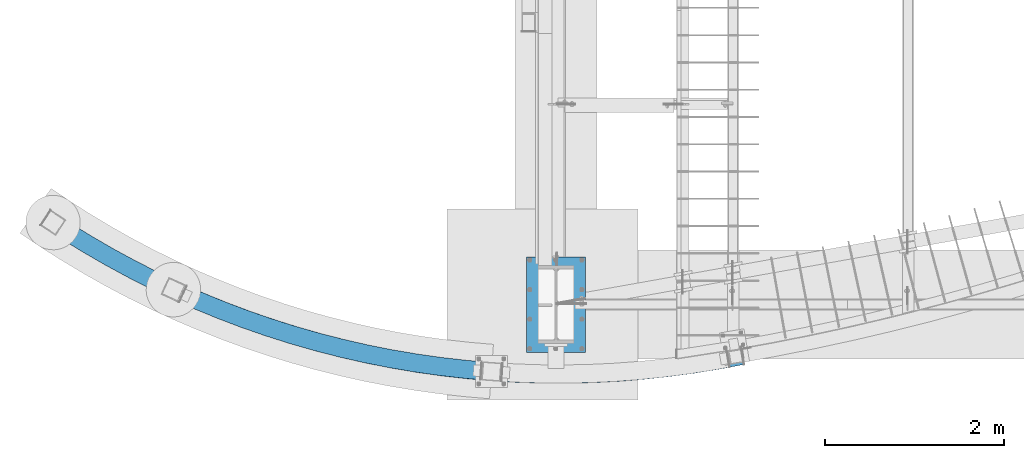
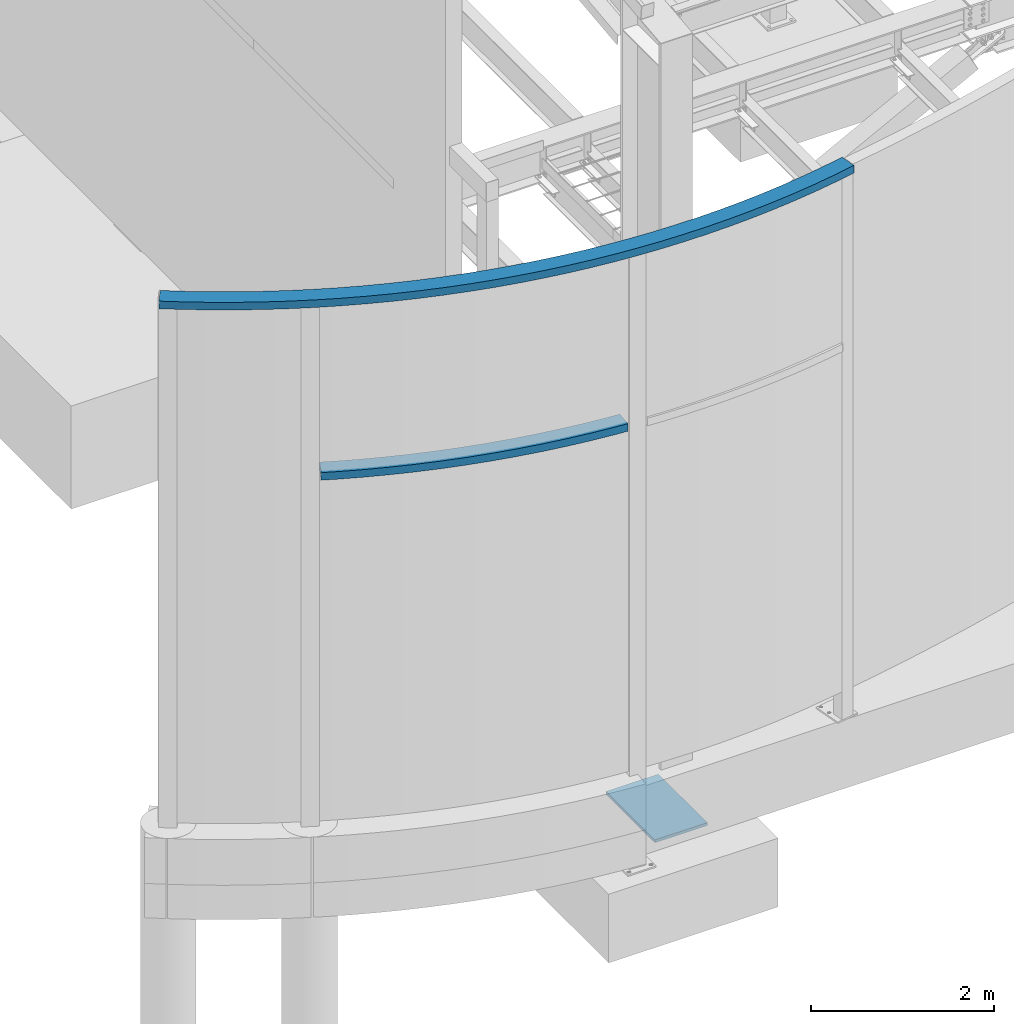
# One storey, part 700 of 1179: 3 beams, 3 elements without a shape of their own.
"""IFC2X3 building model written with IfcOpenShell, lengths in millimetres."""

import ifcopenshell
import ifcopenshell.guid

model = None  # the IFC model being written
_history = None  # IfcOwnerHistory: only IFC2X3 demands one
_inside = {}  # id of a spatial element -> (the spatial element, [elements in it])
_under = {}  # id of a project, library or spatial element -> (it, [spatial elements below it])
_declared = {}  # id of a project -> (the project, [libraries it declares])
_typed = {}  # id of a type object -> (the type object, [elements of that type])
_made_of = {}  # id of a material, layer set ... -> (it, [elements and type objects made of it])


def new_model(schema):
    """Start an empty IFC model of exactly this schema.

    Asked for "IFC4X3", IfcOpenShell would pick the latest addendum, in which some entities
    have other attributes; the version numbers below select the first issue.
    IFC2X3 requires an IfcOwnerHistory on every rooted entity: one is made here for all.
    """
    global model, _history
    if schema == "IFC4X3":
        model = ifcopenshell.file(schema_version=(4, 3, 0, 0))
    else:
        model = ifcopenshell.file(schema=schema)
    _inside.clear()
    _under.clear()
    _declared.clear()
    _typed.clear()
    _made_of.clear()
    _history = None
    if model.schema == "IFC2X3":
        org = make("IfcOrganization", Name="unknown")
        user = make(
            "IfcPersonAndOrganization",
            ThePerson=make("IfcPerson", FamilyName="unknown"),
            TheOrganization=org,
        )
        app = make(
            "IfcApplication",
            ApplicationDeveloper=org,
            Version="unknown",
            ApplicationFullName="unknown",
            ApplicationIdentifier="unknown",
        )
        _history = make(
            "IfcOwnerHistory",
            OwningUser=user,
            OwningApplication=app,
            ChangeAction="ADDED",
            CreationDate=0,
        )
    return model


def make(cls, **values):
    """One entity of the class cls with the attributes given. An attribute that is None is left unset."""
    return model.create_entity(
        cls, **{name: value for name, value in values.items() if value is not None}
    )


def rooted(cls, **values):
    """An entity with a GlobalId (a new one), such as an element, a storey or a relation."""
    return make(cls, GlobalId=ifcopenshell.guid.new(), OwnerHistory=_history, **values)


def si_unit(unit_type, name, prefix=None):
    """IfcSIUnit, for example si_unit("LENGTHUNIT", "METRE", prefix="MILLI")."""
    return make("IfcSIUnit", UnitType=unit_type, Prefix=prefix, Name=name)


def assignment(units):
    """IfcUnitAssignment: the units of a project."""
    return None if units is None else make("IfcUnitAssignment", Units=units)


def point(xyz):
    """IfcCartesianPoint."""
    return None if xyz is None else make("IfcCartesianPoint", Coordinates=xyz)


def direction(xyz):
    """IfcDirection."""
    return None if xyz is None else make("IfcDirection", DirectionRatios=xyz)


def frame(location, z_axis=None, x_axis=None):
    """IfcAxis2Placement3D, a coordinate frame: its origin and axes. An axis left out is left unset."""
    return make(
        "IfcAxis2Placement3D",
        Location=point(location),
        Axis=direction(z_axis),
        RefDirection=direction(x_axis),
    )


def origin_with_axes():
    """The frame at (0, 0, 0) with the z axis (0, 0, 1) and the x axis (1, 0, 0) written out."""
    return frame((0.0, 0.0, 0.0), z_axis=(0.0, 0.0, 1.0), x_axis=(1.0, 0.0, 0.0))


def place(relative_to, where):
    """IfcLocalPlacement: puts the frame where relative to a parent placement (None: the world)."""
    return make(
        "IfcLocalPlacement", PlacementRelTo=relative_to, RelativePlacement=where
    )


def context(
    kind, dimensions, precision=None, world=None, true_north=None, identifier=None
):
    """IfcGeometricRepresentationContext, for example the 3D "Model" context."""
    return make(
        "IfcGeometricRepresentationContext",
        ContextIdentifier=identifier,
        ContextType=kind,
        CoordinateSpaceDimension=dimensions,
        Precision=precision,
        WorldCoordinateSystem=world,
        TrueNorth=true_north,
    )


def subcontext(parent, identifier, kind, view, scale=None):
    """IfcGeometricRepresentationSubContext, for example "Body" below "Model"."""
    return make(
        "IfcGeometricRepresentationSubContext",
        ContextIdentifier=identifier,
        ContextType=kind,
        ParentContext=parent,
        TargetScale=scale,
        TargetView=view,
    )


def project(units=None, contexts=None):
    """IfcProject with its units and contexts."""
    return rooted(
        "IfcProject",
        Name="project",
        RepresentationContexts=contexts,
        UnitsInContext=assignment(units),
    )


def spatial(cls, under=None, at=None, **own):
    """A site, building, storey or space (cls), placed at a placement, below another one or the project."""
    s = rooted(cls, ObjectPlacement=at, **own)
    if under is not None:
        _under.setdefault(under.id(), (under, []))[1].append(s)
    return s


def faces_of(points, faces, orient=None, outer=None):
    """IfcFace entities. A face is a list of loops; a loop is a list of indices into points, from 0.

    orient and outer hold one flag for each loop. By default every Orientation is true, the
    first loop of a face is its IfcFaceOuterBound and the others are IfcFaceBound.
    """
    made = []
    for i, loops in enumerate(faces):
        bounds = []
        for j, loop in enumerate(loops):
            is_outer = j == 0 if outer is None else outer[i][j]
            bounds.append(
                make(
                    "IfcFaceOuterBound" if is_outer else "IfcFaceBound",
                    Bound=make("IfcPolyLoop", Polygon=[points[k] for k in loop]),
                    Orientation=True if orient is None else orient[i][j],
                )
            )
        made.append(make("IfcFace", Bounds=bounds))
    return made


def faceted_brep(points, faces, orient=None, outer=None, voids=None):
    """IfcFacetedBrep: a solid bounded by flat faces; with voids (closed shells), ...WithVoids."""
    shared = [point(p) for p in points]
    hull = make("IfcClosedShell", CfsFaces=faces_of(shared, faces, orient, outer))
    if voids is None:
        return make("IfcFacetedBrep", Outer=hull)
    return make(
        "IfcFacetedBrepWithVoids",
        Outer=hull,
        Voids=[
            make(cls, CfsFaces=faces_of(shared, fs, o, b)) for cls, fs, o, b in voids
        ],
    )


def shape(context_of_items, identifier, shape_type, items):
    """IfcShapeRepresentation: the items that make up one representation, for example the "Body"."""
    return make(
        "IfcShapeRepresentation",
        ContextOfItems=context_of_items,
        RepresentationIdentifier=identifier,
        RepresentationType=shape_type,
        Items=items,
    )


def material(Name=None, Category=None):
    """IfcMaterial."""
    return make("IfcMaterial", Name=Name, Category=Category)


def made_of(thing, what):
    """Note that an element or type object is made of a material, layer set ...; save() writes the relation."""
    if what is not None:
        _made_of.setdefault(what.id(), (what, []))[1].append(thing)
    return thing


def type_object(cls, material=None, **own):
    """A type object (cls), such as IfcWallType, which elements share."""
    return made_of(rooted(cls, **own), material)


def element(
    cls,
    number,
    at=None,
    inside=None,
    cuts=None,
    type_object=None,
    material=None,
    context=None,
    identifier="Body",
    shape_type=None,
    held_by="IfcProductDefinitionShape",
    body=None,
    shapes=None,
    **own,
):
    """One element of the class cls, such as IfcWall. Its Tag is "e" and its number.

    at: its placement. inside: the storey or other place that contains it. cuts: it is an
    opening in that element (IfcRelVoidsElement). A single representation is given by context,
    identifier, shape_type and body (its items); several are given by shapes. held_by: the class
    of the entity that holds the representations. save() writes the other relations.
    """
    e = rooted(cls, Tag="e%d" % number, ObjectPlacement=at, **own)
    if body is not None:
        shapes = [shape(context, identifier, shape_type, body)]
    if shapes is not None:
        e.Representation = make(held_by, Representations=shapes)
    if inside is not None:
        _inside.setdefault(inside.id(), (inside, []))[1].append(e)
    if cuts is not None:
        rooted(
            "IfcRelVoidsElement", RelatingBuildingElement=cuts, RelatedOpeningElement=e
        )
    if type_object is not None:
        _typed.setdefault(type_object.id(), (type_object, []))[1].append(e)
    return made_of(e, material)


def aggregate(whole, parts):
    """IfcRelAggregates: a whole, such as a stair, and the parts it consists of."""
    return rooted("IfcRelAggregates", RelatingObject=whole, RelatedObjects=parts)


def save(model, path):
    """Write the relations noted so far, then the file.

    IfcRelAggregates (storeys below a building ...), IfcRelContainedInSpatialStructure (elements
    in a storey), IfcRelDefinesByType, IfcRelAssociatesMaterial and IfcRelDeclares: one each for
    every whole, place, type object, material and project.
    """
    for whole, parts in _under.values():
        aggregate(whole, parts)
    for where, things in _inside.values():
        rooted(
            "IfcRelContainedInSpatialStructure",
            RelatedElements=things,
            RelatingStructure=where,
        )
    for kind, things in _typed.values():
        rooted("IfcRelDefinesByType", RelatedObjects=things, RelatingType=kind)
    for what, things in _made_of.values():
        rooted("IfcRelAssociatesMaterial", RelatedObjects=things, RelatingMaterial=what)
    for by, libraries in _declared.values():
        rooted("IfcRelDeclares", RelatingContext=by, RelatedDefinitions=libraries)
    model.write(path)


model = new_model("IFC2X3")

# Units and contexts
model_context = context("Model", 3, precision=1e-05, world=origin_with_axes())
body_context = subcontext(model_context, "Body", "Model", "MODEL_VIEW")
ifc_project = project(units=[si_unit("LENGTHUNIT", "METRE", prefix="MILLI"), si_unit("AREAUNIT", "SQUARE_METRE"), si_unit("VOLUMEUNIT", "CUBIC_METRE"), si_unit("MASSUNIT", "GRAM", prefix="KILO"), si_unit("TIMEUNIT", "SECOND"), si_unit("PLANEANGLEUNIT", "RADIAN"), si_unit("SOLIDANGLEUNIT", "STERADIAN"), si_unit("THERMODYNAMICTEMPERATUREUNIT", "DEGREE_CELSIUS"), si_unit("LUMINOUSINTENSITYUNIT", "LUMEN")], contexts=[model_context])

# Site, building, storey
site_placement = place(None, origin_with_axes())
site = spatial("IfcSite", under=ifc_project, at=site_placement, CompositionType="ELEMENT")
building_placement = place(site_placement, origin_with_axes())
building = spatial("IfcBuilding", under=site, at=building_placement, Name="Undefined", CompositionType="ELEMENT")
storey_placement = place(building_placement, origin_with_axes())
storey = spatial("IfcBuildingStorey", under=building, at=storey_placement, Name="Undefined", CompositionType="ELEMENT", Elevation=0.0)

# Assembly, beam
assembly_1_placement = place(storey_placement, origin_with_axes())
assembly_1 = element("IfcElementAssembly", 1, at=assembly_1_placement, inside=storey, Name="BEAM", AssemblyPlace="NOTDEFINED", PredefinedType="RIGID_FRAME")
ifc_material_1 = material()
beam_type_1 = type_object("IfcBeamType", Name="HSS8X4X1/4", PredefinedType="NOTDEFINED")
beam_1_placement = place(assembly_1_placement, frame((-5275.44377890832, 1410.31196065489, 6908.8), z_axis=(0.38393976093835, 0.923358142851734, 0.0), x_axis=(0.923358142851734, -0.38393976093835, 0.0)))
beam_1 = element("IfcBeam", 2, at=beam_1_placement, type_object=beam_type_1, material=ifc_material_1, Name="BEAM", ObjectType="HSS8X4X1/4", context=body_context, shape_type="Brep", body=[
    faceted_brep([(259.218046958578, 50.8000000000002, -151.867784473954), (539.821269490069, 50.8000000000002, -196.459973259438), (539.821269490069, -50.8000000000002, -196.459973259438), (259.218046958578, -50.8000000000002, -151.867784473954), (821.541401207169, 50.8000000000002, -233.343562849296), (821.541401207169, -50.8000000000002, -233.343562849296), (1104.16671573728, 50.8000000000002, -262.490833433148), (1104.16671573728, -50.8000000000002, -262.490833433148), (1387.48480641892, 50.8000000000002, -283.879879420383), (1387.48480641892, -50.8000000000002, -283.879879420383), (1671.28274593564, 50.8000000000002, -297.494625903278), (1671.28274593564, -50.8000000000002, -297.494625903278), (1955.34724634128, 50.8000000000002, -303.32484073808), (1955.34724634128, -50.8000000000002, -303.32484073808), (2239.46481935623, 50.8000000000002, -301.366142234949), (2239.46481935623, -50.8000000000002, -301.366142234949), (2523.42193681419, 50.8000000000002, -291.620002451016), (2523.42193681419, -50.8000000000002, -291.620002451016), (2807.00519113906, 50.8000000000002, -274.093746084063), (2807.00519113906, -50.8000000000002, -274.093746084063), (3090.00145573103, 50.8000000000002, -248.800544967648), (3090.00145573103, -50.8000000000002, -248.800544967648), (3372.19804514161, 50.8000000000002, -215.759408171846), (3372.19804514161, -50.8000000000002, -215.759408171846), (3653.38287491708, 50.8000000000002, -174.995167716991), (3653.38287491708, -50.8000000000002, -174.995167716991), (3933.34462099027, 50.8000000000002, -126.53845991122), (3933.34462099027, -50.8000000000002, -126.53845991122), (4211.87287850084, 50.8000000000002, -70.4257023257936), (4211.87287850084, -50.8000000000002, -70.4257023257936), (4488.75831992482, 50.8000000000002, -6.69906642551973), (4488.75831992482, -50.8000000000002, -6.69906642551973), (4763.79285239436, 50.8000000000002, 64.5935541251514), (4763.79285239436, -50.8000000000002, 64.5935541251514), (5036.76977408965, 50.8000000000002, 143.398579456546), (5036.76977408965, -50.8000000000002, 143.398579456546), (5307.48392958539, 50.8000000000002, 229.656783761633), (5307.48392958539, -50.8000000000002, 229.656783761633), (5575.73186403511, 50.8000000000002, 323.303339807115), (5575.73186403511, -50.8000000000002, 323.303339807115), (5841.31197607726, 50.8000000000002, 424.267867654227), (5841.31197607726, -50.8000000000002, 424.267867654227), (6104.02466934857, 50.8000000000002, 532.474487552688), (6104.02466934857, -50.8000000000002, 532.474487552688), (6363.67250249031, 50.8000000000002, 647.841876968034), (6363.67250249031, -50.8000000000002, 647.841876968034), (6620.06033753513, 50.8000000000002, 770.283331699435), (6620.06033753513, -50.8000000000002, 770.283331699435), (6872.99548656272, 50.8000000000002, 899.706831042125), (6872.99548656272, -50.8000000000002, 899.706831042125), (7122.2878565141, 50.8000000000002, 1036.01510694544), (7122.2878565141, -50.8000000000002, 1036.01510694544), (7367.75009205587, 50.8000000000002, 1179.10571711448), (7367.75009205587, -50.8000000000002, 1179.10571711448), (7609.1977163868, 50.8000000000002, 1328.87112200047), (7609.1977163868, -50.8000000000002, 1328.87112200047), (7499.73163759643, 50.8000000000002, 1500.06521533977), (7499.73163759643, -50.8000000000002, 1500.06521533977), (7730.0422105149, -50.8000000000002, 1651.81937094037), (7730.0422105149, 50.8000000000002, 1651.81937094037), (7263.01788799386, -50.8000000000002, 1353.23614361231), (7263.01788799386, 50.8000000000002, 1353.23614361231), (7022.36823852254, -50.8000000000002, 1212.95099912231), (7022.36823852254, 50.8000000000002, 1212.95099912231), (6777.96354909134, -50.8000000000002, 1079.31521297471), (6777.96354909134, 50.8000000000002, 1079.31521297471), (6529.98750170418, -50.8000000000002, 952.429218958454), (6529.98750170418, 50.8000000000002, 952.429218958454), (6278.62646241409, -50.8000000000002, 832.388378065614), (6278.62646241409, 50.8000000000002, 832.388378065614), (6024.06934126005, -50.8000000000002, 719.282906822975), (6024.06934126005, 50.8000000000002, 719.282906822975), (5766.50745029191, -50.8000000000002, 613.197809489906), (5766.50745029191, 50.8000000000002, 613.197809489905), (5506.13435979008, -50.8000000000002, 514.212814173549), (5506.13435979008, 50.8000000000002, 514.212814173548), (5243.14575278807, -50.8000000000002, 422.402312909265), (5243.14575278807, 50.8000000000002, 422.402312909265), (4977.73927800719, -50.8000000000002, 337.835305751407), (4977.73927800719, 50.8000000000002, 337.835305751407), (4710.11440131387, -50.8000000000002, 260.575348916414), (4710.11440131387, 50.8000000000002, 260.575348916414), (4440.47225581146, -50.8000000000002, 190.680507017236), (4440.47225581146, 50.8000000000002, 190.680507017236), (4169.01549067883, -50.8000000000002, 128.203309424948), (4169.01549067883, 50.8000000000002, 128.203309424948), (3895.94811886973, -50.8000000000002, 73.1907107903846), (3895.94811886973, 50.8000000000002, 73.1907107903846), (3621.4753637871, -50.8000000000002, 25.6840557554291), (3621.4753637871, 50.8000000000002, 25.6840557554275), (3345.80350504773, -50.8000000000002, -14.2809521195055), (3345.80350504773, 50.8000000000002, -14.2809521195055), (3069.1397234531, -50.8000000000002, -46.6742771884062), (3069.1397234531, 50.8000000000002, -46.6742771884062), (2791.69194528292, -50.8000000000002, -71.47157429294), (2791.69194528292, 50.8000000000002, -71.4715742929404), (2513.66868602843, -50.8000000000002, -88.6542070590068), (2513.66868602843, 50.8000000000002, -88.6542070590068), (2235.27889368289, -50.8000000000002, -98.2092619028816), (2235.27889368289, 50.8000000000002, -98.2092619028814), (1956.73179170698, -50.8000000000002, -100.129557736408), (1956.73179170698, 50.8000000000002, -100.129557736408), (1678.23672178722, -50.8000000000002, -94.4136513639239), (1678.23672178722, 50.8000000000002, -94.4136513639239), (1400.00298650553, -50.8000000000002, -81.0658385669027), (1400.00298650553, 50.8000000000002, -81.0658385669027), (1122.23969203811, -50.8000000000002, -60.0961508754618), (1122.23969203811, 50.8000000000002, -60.0961508754616), (845.155591002052, -50.8000000000002, -31.5203480291747), (845.155591002052, 50.8000000000002, -31.5203480291761), (568.958925567555, -50.8000000000002, 4.64009386712303), (568.958925567555, 50.8000000000002, 4.64009386712144), (293.857270953826, -50.8000000000002, 48.3579984836948), (293.857270953826, 50.8000000000002, 48.3579984836948), (25.4080125181054, 50.8000000000002, 98.5991218713883), (25.4080125181054, -50.8000000000002, 98.5991218713883), (7838.72166228527, -50.8000000000002, 1480.10696045358), (-12.9228285404379, -50.8000000000002, -100.935763337249), (-12.9228285404379, 50.8000000000002, -100.935763337249), (7838.72166228527, 50.8000000000002, 1480.10696045358), (260.30052270843, -44.4499999999998, -145.610728756527), (540.731821242491, -44.4499999999998, -190.175596161732), (540.731821242491, 44.4499999999998, -190.175596161732), (260.300522708431, 44.4499999999998, -145.610728756527), (822.279344638257, -44.4499999999998, -227.036587386168), (822.279344638258, 44.4499999999998, -227.036587386168), (1104.73149624668, -44.4499999999998, -256.165999603222), (1104.73149624668, 44.4499999999998, -256.165999603222), (1387.87599954662, -44.4499999999998, -277.541940643712), (1387.87599954662, 44.4499999999998, -277.541940643712), (1671.500057681, -44.4499999999998, -291.148345448925), (1671.500057681, 44.4499999999998, -291.148345448925), (1955.39051338396, -44.4499999999998, -296.974988144278), (1955.39051338396, 44.4499999999998, -296.974988144278), (2239.33400917893, -44.4499999999998, -295.017489724572), (2239.33400917893, 44.4499999999998, -295.017489724572), (2523.11714772714, -44.4499999999998, -285.277321345015), (2523.11714772714, 44.4499999999998, -285.277321345015), (2806.52665220606, -44.4499999999998, -267.761803215588), (2806.52665220606, 44.4499999999998, -267.761803215588), (3089.34952659735, -44.4499999999998, -242.484099099546), (3089.34952659735, 44.4499999999998, -242.484099099546), (3371.37321576368, -44.4499999999998, -209.46320642021), (3371.37321576368, 44.4499999999998, -209.463206420209), (3652.38576519427, -44.4499999999998, -168.723941983478), (3652.38576519427, 44.4499999999998, -168.723941983478), (3932.175980299, -44.4499999999998, -120.296923326795), (3932.175980299, 44.4499999999998, -120.296923326795), (4210.53358513141, -44.4499999999998, -64.2185457085832), (4210.53358513141, 44.4499999999998, -64.218545708583), (4487.24938042128, -44.4499999999998, -0.530954755433982), (4487.24938042128, 44.4499999999998, -0.530954755433982), (4762.11540079809, -44.4499999999998, 70.7179852123787), (4762.11540079809, 44.4499999999998, 70.7179852123787), (5034.92507108707, -44.4499999999998, 149.47472715326), (5034.92507108707, 44.4499999999998, 149.47472715326), (5305.47336156048, -44.4499999999998, 235.680081547496), (5305.47336156048, 44.4499999999998, 235.680081547496), (5573.55694202745, -44.4499999999998, 329.269260881064), (5573.55694202745, 44.4499999999998, 329.269260881064), (5838.97433464647, -44.4499999999998, 430.17192833659), (5838.97433464647, 44.4499999999998, 430.17192833659), (6101.5260653458, -44.4499999999998, 538.312250654885), (6101.5260653458, 44.4499999999998, 538.312250654885), (6361.01481373792, -44.4499999999998, 653.608955127335), (6361.01481373792, 44.4499999999998, 653.608955127335), (6617.24556141542, -44.4499999999998, 775.97539067628), (6617.24556141542, 44.4499999999998, 775.97539067628), (6870.02573851674, -44.4499999999998, 905.31959297752), (6870.02573851674, 44.4499999999998, 905.31959297752), (7119.16536845186, -44.4499999999998, 1041.54435357597), (7119.16536845186, 44.4499999999998, 1041.54435357597), (7364.47721067893, -44.4499999999998, 1184.54729294253), (7364.47721067893, 44.4499999999998, 1184.54729294253), (7605.7769014246, -44.4499999999998, 1334.22093741732), (7605.7769014246, 44.4499999999998, 1334.22093741732), (7835.32542941745, -44.4499999999998, 1485.47297328129), (7835.32542941745, 44.4499999999998, 1485.47297328129), (7733.43844338272, 44.4499999999998, 1646.45335811266), (7733.43844338272, -44.4499999999998, 1646.45335811266), (7503.15245255863, -44.4499999999998, 1494.71539992292), (7503.15245255863, 44.4499999999998, 1494.71539992292), (7266.2907693708, 44.4499999999998, 1347.79456778426), (7266.2907693708, -44.4499999999998, 1347.79456778426), (7025.49072658478, 44.4499999999998, 1207.42175249178), (7025.49072658478, -44.4499999999998, 1207.42175249178), (6780.93329713732, 44.4499999999998, 1073.70245103932), (6780.93329713732, -44.4499999999998, 1073.70245103932), (6532.8022778239, 44.4499999999998, 946.737159981609), (6532.8022778239, -44.4499999999998, 946.737159981609), (6281.28415116647, 44.4499999999998, 826.621299906316), (6281.28415116647, -44.4499999999998, 826.621299906316), (6026.56794526282, 44.4499999999998, 713.445143720777), (6026.56794526282, -44.4499999999998, 713.445143720777), (5768.8450917227, 44.4499999999998, 607.293748807541), (5768.8450917227, -44.4499999999998, 607.293748807541), (5508.30928179773, 44.4499999999998, 508.246893099596), (5508.30928179773, -44.4499999999998, 508.246893099596), (5245.15632081299, 44.4499999999998, 416.3790151234), (5245.15632081299, -44.4499999999998, 416.3790151234), (4979.58398100976, 44.4499999999998, 331.759158054693), (4979.58398100976, -44.4499999999998, 331.759158054693), (4711.79185291014, 44.4499999999998, 254.450917829186), (4711.79185291014, -44.4499999999998, 254.450917829186), (4441.981195315, 44.4499999999998, 184.512395347151), (4441.981195315, -44.4499999999998, 184.512395347151), (4170.35478404827, 44.4499999999998, 121.996152807739), (4170.35478404827, -44.4499999999998, 121.996152807739), (3897.11675956099, 44.4499999999998, 66.9491742059616), (3897.11675956099, -44.4499999999998, 66.9491742059616), (3622.47247350991, 44.4499999999998, 19.4128300219157), (3622.47247350991, -44.4499999999998, 19.4128300219157), (3346.62833442567, 44.4499999999998, -20.57715387114), (3346.62833442567, -44.4499999999998, -20.57715387114), (3069.79165258679, 44.4499999999998, -52.9907230565086), (3069.79165258679, -44.4499999999998, -52.9907230565086), (2792.17048421593, 44.4499999999998, -77.8035171614137), (2792.17048421593, -44.4499999999998, -77.8035171614137), (2513.97347511548, 44.4499999999998, -94.9968881650074), (2513.97347511548, -44.4499999999998, -94.9968881650074), (2235.40970386018, 44.4499999999998, -104.55791441326), (2235.40970386018, -44.4499999999998, -104.55791441326), (1956.6885246643, 44.4499999999998, -106.47941033021), (1956.6885246643, -44.4499999999998, -106.47941033021), (1678.01941004186, 44.4499999999998, -100.759931818277), (1678.01941004186, -44.4499999999998, -100.759931818277), (1399.61179337782, 44.4499999999998, -87.4037773435717), (1399.61179337782, -44.4499999999998, -87.4037773435717), (1121.67491152871, 44.4499999999998, -66.4209847053868), (1121.67491152871, -44.4499999999998, -66.4209847053868), (844.417647570961, 44.4499999999998, -37.8273234923045), (844.417647570961, -44.4499999999998, -37.8273234923045), (568.048373815134, 44.4499999999998, -1.64428323058257), (568.048373815134, -44.4499999999998, -1.64428323058257), (292.774795203974, 44.4499999999998, 42.1009427662683), (292.774795203974, -44.4499999999998, 42.1009427662683), (24.2101737350258, -44.4499999999998, 92.3636567086172), (24.2101737350258, 44.4499999999998, 92.3636567086172), (-11.7249897573593, 44.4499999999998, -94.7002981744794), (-11.7249897573593, -44.4499999999998, -94.7002981744796)], [[[0, 1, 2, 3]], [[1, 4, 5, 2]], [[4, 6, 7, 5]], [[6, 8, 9, 7]], [[8, 10, 11, 9]], [[10, 12, 13, 11]], [[12, 14, 15, 13]], [[14, 16, 17, 15]], [[16, 18, 19, 17]], [[18, 20, 21, 19]], [[20, 22, 23, 21]], [[22, 24, 25, 23]], [[24, 26, 27, 25]], [[26, 28, 29, 27]], [[28, 30, 31, 29]], [[30, 32, 33, 31]], [[32, 34, 35, 33]], [[34, 36, 37, 35]], [[36, 38, 39, 37]], [[38, 40, 41, 39]], [[40, 42, 43, 41]], [[42, 44, 45, 43]], [[44, 46, 47, 45]], [[46, 48, 49, 47]], [[48, 50, 51, 49]], [[50, 52, 53, 51]], [[52, 54, 55, 53]], [[56, 57, 58, 59]], [[60, 57, 56, 61]], [[62, 60, 61, 63]], [[64, 62, 63, 65]], [[66, 64, 65, 67]], [[68, 66, 67, 69]], [[70, 68, 69, 71]], [[72, 70, 71, 73]], [[74, 72, 73, 75]], [[76, 74, 75, 77]], [[78, 76, 77, 79]], [[80, 78, 79, 81]], [[82, 80, 81, 83]], [[84, 82, 83, 85]], [[86, 84, 85, 87]], [[88, 86, 87, 89]], [[90, 88, 89, 91]], [[92, 90, 91, 93]], [[94, 92, 93, 95]], [[96, 94, 95, 97]], [[98, 96, 97, 99]], [[100, 98, 99, 101]], [[102, 100, 101, 103]], [[104, 102, 103, 105]], [[106, 104, 105, 107]], [[108, 106, 107, 109]], [[110, 108, 109, 111]], [[112, 110, 111, 113]], [[112, 113, 114, 115]], [[3, 2, 5, 7, 9, 11, 13, 15, 17, 19, 21, 23, 25, 27, 29, 31, 33, 35, 37, 39, 41, 43, 45, 47, 49, 51, 53, 55, 116, 58, 57, 60, 62, 64, 66, 68, 70, 72, 74, 76, 78, 80, 82, 84, 86, 88, 90, 92, 94, 96, 98, 100, 102, 104, 106, 108, 110, 112, 115, 117]], [[0, 3, 117, 118]], [[113, 111, 109, 107, 105, 103, 101, 99, 97, 95, 93, 91, 89, 87, 85, 83, 81, 79, 77, 75, 73, 71, 69, 67, 65, 63, 61, 56, 59, 119, 54, 52, 50, 48, 46, 44, 42, 40, 38, 36, 34, 32, 30, 28, 26, 24, 22, 20, 18, 16, 14, 12, 10, 8, 6, 4, 1, 0, 118, 114]], [[55, 54, 119, 116]], [[120, 121, 122, 123]], [[121, 124, 125, 122]], [[124, 126, 127, 125]], [[126, 128, 129, 127]], [[128, 130, 131, 129]], [[130, 132, 133, 131]], [[132, 134, 135, 133]], [[134, 136, 137, 135]], [[136, 138, 139, 137]], [[138, 140, 141, 139]], [[140, 142, 143, 141]], [[142, 144, 145, 143]], [[144, 146, 147, 145]], [[146, 148, 149, 147]], [[148, 150, 151, 149]], [[150, 152, 153, 151]], [[152, 154, 155, 153]], [[154, 156, 157, 155]], [[156, 158, 159, 157]], [[158, 160, 161, 159]], [[160, 162, 163, 161]], [[162, 164, 165, 163]], [[164, 166, 167, 165]], [[166, 168, 169, 167]], [[168, 170, 171, 169]], [[170, 172, 173, 171]], [[172, 174, 175, 173]], [[175, 174, 176, 177]], [[59, 58, 116, 119], [178, 177, 176, 179]], [[180, 181, 178, 179]], [[182, 181, 180, 183]], [[184, 182, 183, 185]], [[186, 184, 185, 187]], [[188, 186, 187, 189]], [[190, 188, 189, 191]], [[192, 190, 191, 193]], [[194, 192, 193, 195]], [[196, 194, 195, 197]], [[198, 196, 197, 199]], [[200, 198, 199, 201]], [[202, 200, 201, 203]], [[204, 202, 203, 205]], [[206, 204, 205, 207]], [[208, 206, 207, 209]], [[210, 208, 209, 211]], [[212, 210, 211, 213]], [[214, 212, 213, 215]], [[216, 214, 215, 217]], [[218, 216, 217, 219]], [[220, 218, 219, 221]], [[222, 220, 221, 223]], [[224, 222, 223, 225]], [[226, 224, 225, 227]], [[228, 226, 227, 229]], [[230, 228, 229, 231]], [[232, 230, 231, 233]], [[234, 232, 233, 235]], [[234, 235, 236, 237]], [[123, 122, 125, 127, 129, 131, 133, 135, 137, 139, 141, 143, 145, 147, 149, 151, 153, 155, 157, 159, 161, 163, 165, 167, 169, 171, 173, 175, 177, 178, 181, 182, 184, 186, 188, 190, 192, 194, 196, 198, 200, 202, 204, 206, 208, 210, 212, 214, 216, 218, 220, 222, 224, 226, 228, 230, 232, 234, 237, 238]], [[120, 123, 238, 239]], [[235, 233, 231, 229, 227, 225, 223, 221, 219, 217, 215, 213, 211, 209, 207, 205, 203, 201, 199, 197, 195, 193, 191, 189, 187, 185, 183, 180, 179, 176, 174, 172, 170, 168, 166, 164, 162, 160, 158, 156, 154, 152, 150, 148, 146, 144, 142, 140, 138, 136, 134, 132, 130, 128, 126, 124, 121, 120, 239, 236]], [[118, 117, 115, 114], [238, 237, 236, 239]]]),
])
aggregate(assembly_1, [beam_1])

assembly_2_placement = place(storey_placement, origin_with_axes())
assembly_2 = element("IfcElementAssembly", 3, at=assembly_2_placement, inside=storey, Name="BEAM", AssemblyPlace="NOTDEFINED", PredefinedType="RIGID_FRAME")
beam_2_placement = place(assembly_2_placement, frame((-3844.53874525563, 604.29605066735, 4603.75), z_axis=(0.338878348004194, 0.940830200011643, 0.0), x_axis=(0.940830200011643, -0.338878348004194, 0.0)))
beam_2 = element("IfcBeam", 4, at=beam_2_placement, type_object=beam_type_1, material=ifc_material_1, Name="BEAM", ObjectType="HSS8X4X1/4", context=body_context, shape_type="Brep", body=[
    faceted_brep([(3405.89503703432, -50.8000000000002, 171.939905108994), (3405.89503703432, 50.8000000000002, 171.939905108994), (3568.07746758842, 50.8000000000002, 215.195680638788), (3568.07746758842, -50.8000000000002, 215.195680638788), (3356.26580701646, 50.8000000000002, 368.986040640333), (3356.26580701646, -50.8000000000002, 368.986040640333), (3512.71984198563, -50.8000000000002, 410.713992270085), (3512.71984198563, 50.8000000000002, 410.713992270085), (3082.71331555177, -50.8000000000002, 304.119873019658), (3082.71331555177, 50.8000000000002, 304.119873019658), (3126.84252017364, 50.8000000000002, 105.769543301148), (3126.84252017364, -50.8000000000002, 105.769543301148), (2807.46241669617, -50.8000000000002, 246.887644620625), (2807.46241669617, 50.8000000000002, 246.887644620625), (2846.05744787342, 50.8000000000002, 47.3866081109664), (2846.05744787342, -50.8000000000002, 47.3866081109664), (2563.75709715886, 50.8000000000002, -3.16372259515856), (2563.75709715886, -50.8000000000002, -3.16372259515856), (2530.72610502234, -50.8000000000002, 197.333642870021), (2530.72610502235, 50.8000000000002, 197.333642870021), (2280.15991760748, 50.8000000000002, -45.8423319746266), (2280.15991760748, -50.8000000000002, -45.8423319746266), (2252.71852454469, -50.8000000000002, 155.496213631456), (2252.71852454469, 50.8000000000002, 155.496213631456), (1973.65480301046, -50.8000000000002, 121.407731532592), (1973.65480301046, 50.8000000000002, 121.407731532592), (1995.48536230851, 50.8000000000002, -80.616194477999), (1995.48536230851, -50.8000000000002, -80.616194477999), (1693.75088542972, -50.8000000000002, 95.0945749130003), (1693.75088542972, 50.8000000000002, 95.0945749130003), (1709.95371804581, 50.8000000000002, -107.458401404836), (1709.95371804581, -50.8000000000002, -107.458401404836), (1423.78593483555, 50.8000000000002, -126.348181726162), (1423.78593483555, -50.8000000000002, -126.348181726162), (1413.22336697276, -50.8000000000002, 76.5771054120888), (1413.22336697276, 50.8000000000002, 76.5771054120888), (1137.20345495075, 50.8000000000002, -137.27091815752), (1137.20345495075, -50.8000000000002, -137.27091815752), (1132.28932536455, -50.8000000000002, 65.8696522128713), (1132.28932536455, 50.8000000000002, 65.8696522128713), (851.166152905686, -50.8000000000002, 62.9805009537503), (851.166152905686, 50.8000000000002, 62.98050095375), (850.428041564936, 50.8000000000002, -140.218158470092), (850.428041564936, -50.8000000000002, -140.218158470092), (570.07138824993, -50.8000000000002, 67.9118873169351), (570.07138824993, 50.8000000000002, 67.911887316935), (563.681607147339, 50.8000000000002, -135.187622031212), (563.681607147339, -50.8000000000002, -135.187622031212), (277.186041742716, 50.8000000000002, -122.183201569165), (277.186041742716, -50.8000000000002, -122.183201569165), (289.222548068544, -50.8000000000002, 80.6599952984275), (289.222548068544, 50.8000000000002, 80.6599952984275), (127.590527132236, -50.8000000000002, 92.5091795552042), (109.921367289396, -50.8000000000002, -109.921089546027), (109.921367289396, 50.8000000000002, -109.921089546027), (127.590527132236, 50.8000000000002, 92.5091795552042), (288.846407245861, 44.4499999999998, 74.3211453963153), (288.846407245861, -44.4499999999998, 74.3211453963153), (127.038365887147, -44.4499999999998, 86.18323364579), (127.038365887147, 44.4499999999998, 86.18323364579), (277.562182565398, -44.4499999999998, -115.844351667051), (277.562182565399, 44.4499999999998, -115.844351667053), (110.473528534485, 44.4499999999998, -103.595143636614), (110.473528534485, -44.4499999999998, -103.595143636613), (569.871707590475, -44.4499999999998, 61.5650276498042), (851.143086926288, -44.4499999999998, 56.6305428467543), (1132.44289191412, -44.4499999999998, 59.5215093887963), (1413.55344721848, -44.4499999999998, 70.2356901890179), (1694.25722394897, -44.4499999999998, 88.7647944030679), (1974.33700798853, -44.4499999999998, 115.094483844763), (2253.5760680779, -44.4499999999998, 149.204384081267), (2531.75832352661, -44.4499999999998, 191.068100199234), (2808.66851142046, -44.4499999999998, 240.653237229699), (3084.0923531962, -44.4499999999998, 297.921425215955), (3357.81672045452, -44.4499999999998, 362.828348904979), (3514.44976778571, -44.4499999999998, 404.604045031606), (3566.34754178834, -44.4499999999998, 221.305627877265), (3404.34412359627, -44.4499999999998, 178.097596844348), (3125.46348252921, -44.4499999999998, 111.967991104851), (2844.85135314913, -44.4499999999998, 53.6210155018938), (2562.72487865459, -44.4499999999998, 3.10182007562855), (2279.30237407426, -44.4499999999998, -39.5505024244362), (1994.80315733045, -44.4499999999998, -74.3029467901678), (1709.44737952656, -44.4499999999998, -101.128620894903), (1423.45585458983, -44.4499999999998, -120.006766503093), (1137.04988840118, -44.4499999999998, -130.922775333445), (850.451107544334, -44.4499999999998, -133.868200363096), (563.881287806795, -44.4499999999998, -128.840762364081), (563.881287806795, 44.4499999999998, -128.840762364081), (850.451107544335, 44.4499999999998, -133.868200363096), (1137.04988840118, 44.4499999999998, -130.922775333445), (1423.45585458983, 44.4499999999998, -120.006766503093), (1709.44737952656, 44.4499999999998, -101.128620894903), (1994.80315733045, 44.4499999999998, -74.3029467901678), (2279.30237407426, 44.4499999999998, -39.5505024244362), (2562.72487865459, 44.4499999999998, 3.10182007562844), (2844.85135314913, 44.4499999999998, 53.6210155018938), (3125.46348252921, 44.4499999999998, 111.967991104851), (3404.34412359627, 44.4499999999998, 178.097596844348), (3566.34754178834, 44.4499999999998, 221.305627877265), (3514.44976778571, 44.4499999999998, 404.604045031606), (3357.81672045452, 44.4499999999998, 362.828348904979), (3084.0923531962, 44.4499999999998, 297.921425215955), (2808.66851142046, 44.4499999999998, 240.653237229699), (2531.75832352661, 44.4499999999998, 191.068100199234), (2253.5760680779, 44.4499999999998, 149.204384081267), (1974.33700798853, 44.4499999999998, 115.094483844763), (1694.25722394897, 44.4499999999998, 88.7647944030679), (1413.55344721848, 44.4499999999998, 70.2356901890179), (1132.44289191412, 44.4499999999998, 59.5215093887963), (851.143086926288, 44.4499999999998, 56.6305428467543), (569.871707590475, 44.4499999999998, 61.5650276498042)], [[[0, 1, 2, 3]], [[4, 5, 6, 7]], [[8, 5, 4, 9]], [[10, 1, 0, 11]], [[12, 8, 9, 13]], [[14, 10, 11, 15]], [[16, 14, 15, 17]], [[18, 12, 13, 19]], [[20, 16, 17, 21]], [[22, 18, 19, 23]], [[24, 22, 23, 25]], [[26, 20, 21, 27]], [[28, 24, 25, 29]], [[30, 26, 27, 31]], [[32, 30, 31, 33]], [[34, 28, 29, 35]], [[36, 32, 33, 37]], [[38, 34, 35, 39]], [[40, 38, 39, 41]], [[42, 36, 37, 43]], [[44, 40, 41, 45]], [[46, 42, 43, 47]], [[48, 46, 47, 49]], [[50, 44, 45, 51]], [[49, 47, 43, 37, 33, 31, 27, 21, 17, 15, 11, 0, 3, 6, 5, 8, 12, 18, 22, 24, 28, 34, 38, 40, 44, 50, 52, 53]], [[48, 49, 53, 54]], [[51, 45, 41, 39, 35, 29, 25, 23, 19, 13, 9, 4, 7, 2, 1, 10, 14, 16, 20, 26, 30, 32, 36, 42, 46, 48, 54, 55]], [[50, 51, 55, 52]], [[56, 57, 58, 59]], [[60, 61, 62, 63]], [[57, 64, 65, 66, 67, 68, 69, 70, 71, 72, 73, 74, 75, 76, 77, 78, 79, 80, 81, 82, 83, 84, 85, 86, 87, 60, 63, 58]], [[54, 53, 52, 55], [62, 59, 58, 63]], [[61, 88, 89, 90, 91, 92, 93, 94, 95, 96, 97, 98, 99, 100, 101, 102, 103, 104, 105, 106, 107, 108, 109, 110, 111, 56, 59, 62]], [[60, 87, 88, 61]], [[56, 111, 64, 57]], [[111, 110, 65, 64]], [[87, 86, 89, 88]], [[110, 109, 66, 65]], [[86, 85, 90, 89]], [[85, 84, 91, 90]], [[109, 108, 67, 66]], [[84, 83, 92, 91]], [[108, 107, 68, 67]], [[107, 106, 69, 68]], [[83, 82, 93, 92]], [[106, 105, 70, 69]], [[82, 81, 94, 93]], [[81, 80, 95, 94]], [[105, 104, 71, 70]], [[80, 79, 96, 95]], [[104, 103, 72, 71]], [[103, 102, 73, 72]], [[79, 78, 97, 96]], [[102, 101, 74, 73]], [[78, 77, 98, 97]], [[98, 77, 76, 99]], [[74, 101, 100, 75]], [[7, 6, 3, 2], [100, 99, 76, 75]]]),
])
aggregate(assembly_2, [beam_2])

assembly_3_placement = place(storey_placement, origin_with_axes())
assembly_3 = element("IfcElementAssembly", 5, at=assembly_3_placement, inside=storey, Name="COLUMN", AssemblyPlace="NOTDEFINED", PredefinedType="RIGID_FRAME")
ifc_material_2 = material(Name="STEEL/A572-GR.50")
beam_type_2 = type_object("IfcBeamType", PredefinedType="NOTDEFINED")
beam_3_placement = place(assembly_3_placement, frame((431.800000000003, -95.25, -1276.35), z_axis=(-1.0, 0.0, 0.0), x_axis=(0.0, 1.0, 0.0)))
beam_3 = element("IfcBeam", 6, at=beam_3_placement, type_object=beam_type_2, material=ifc_material_2, context=body_context, shape_type="Brep", body=[
    faceted_brep([(0.0, 19.05, -330.200000000001), (0.0, 19.05, 330.2), (1066.80000000029, 19.05, 330.2), (1066.80000000029, 19.05, -330.200000000001), (0.0, -19.05, 330.2), (1066.80000000029, -19.05, 330.2), (0.0, -19.05, -330.200000000001), (1066.80000000029, -19.05, -330.200000000001)], [[[0, 1, 2, 3]], [[1, 4, 5, 2]], [[4, 6, 7, 5]], [[6, 0, 3, 7]], [[5, 7, 3, 2]], [[6, 4, 1, 0]]]),
])
aggregate(assembly_3, [beam_3])

save(model, "model.ifc")
